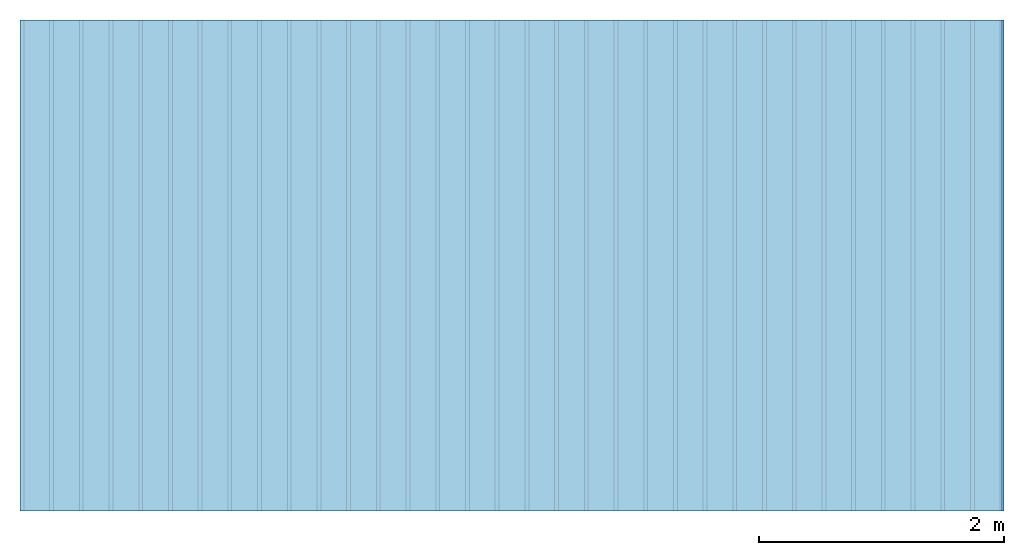
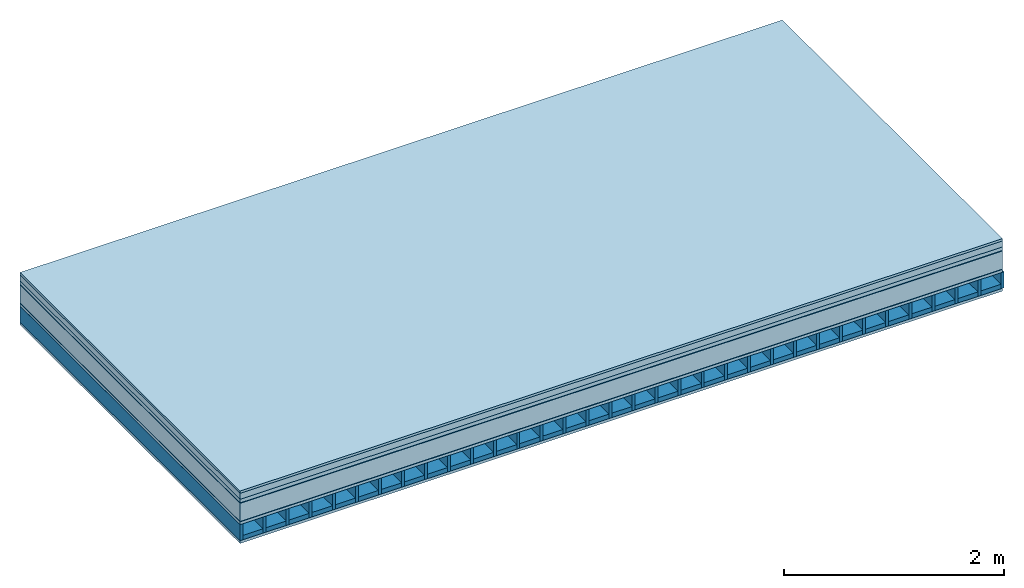
# One storey: 8 plates, 2 members, 1 element without a shape of its own.
"""IFC4 building model written with IfcOpenShell, lengths in metres."""

import ifcopenshell
import ifcopenshell.guid

model = None  # the IFC model being written
_history = None  # IfcOwnerHistory: only IFC2X3 demands one
_inside = {}  # id of a spatial element -> (the spatial element, [elements in it])
_under = {}  # id of a project, library or spatial element -> (it, [spatial elements below it])
_declared = {}  # id of a project -> (the project, [libraries it declares])
_typed = {}  # id of a type object -> (the type object, [elements of that type])
_made_of = {}  # id of a material, layer set ... -> (it, [elements and type objects made of it])


def new_model(schema):
    """Start an empty IFC model of exactly this schema.

    Asked for "IFC4X3", IfcOpenShell would pick the latest addendum, in which some entities
    have other attributes; the version numbers below select the first issue.
    IFC2X3 requires an IfcOwnerHistory on every rooted entity: one is made here for all.
    """
    global model, _history
    if schema == "IFC4X3":
        model = ifcopenshell.file(schema_version=(4, 3, 0, 0))
    else:
        model = ifcopenshell.file(schema=schema)
    _inside.clear()
    _under.clear()
    _declared.clear()
    _typed.clear()
    _made_of.clear()
    _history = None
    if model.schema == "IFC2X3":
        org = make("IfcOrganization", Name="unknown")
        user = make(
            "IfcPersonAndOrganization",
            ThePerson=make("IfcPerson", FamilyName="unknown"),
            TheOrganization=org,
        )
        app = make(
            "IfcApplication",
            ApplicationDeveloper=org,
            Version="unknown",
            ApplicationFullName="unknown",
            ApplicationIdentifier="unknown",
        )
        _history = make(
            "IfcOwnerHistory",
            OwningUser=user,
            OwningApplication=app,
            ChangeAction="ADDED",
            CreationDate=0,
        )
    return model


def make(cls, **values):
    """One entity of the class cls with the attributes given. An attribute that is None is left unset."""
    return model.create_entity(
        cls, **{name: value for name, value in values.items() if value is not None}
    )


def rooted(cls, **values):
    """An entity with a GlobalId (a new one), such as an element, a storey or a relation."""
    return make(cls, GlobalId=ifcopenshell.guid.new(), OwnerHistory=_history, **values)


def si_unit(unit_type, name, prefix=None):
    """IfcSIUnit, for example si_unit("LENGTHUNIT", "METRE", prefix="MILLI")."""
    return make("IfcSIUnit", UnitType=unit_type, Prefix=prefix, Name=name)


def derived_unit(unit_type, elements):
    """IfcDerivedUnit: a product of units, each with its exponent."""
    return make(
        "IfcDerivedUnit",
        Elements=[
            make("IfcDerivedUnitElement", Unit=unit, Exponent=power)
            for unit, power in elements
        ],
        UnitType=unit_type,
    )


def assignment(units):
    """IfcUnitAssignment: the units of a project."""
    return None if units is None else make("IfcUnitAssignment", Units=units)


def point(xyz):
    """IfcCartesianPoint."""
    return None if xyz is None else make("IfcCartesianPoint", Coordinates=xyz)


def direction(xyz):
    """IfcDirection."""
    return None if xyz is None else make("IfcDirection", DirectionRatios=xyz)


def frame(location, z_axis=None, x_axis=None):
    """IfcAxis2Placement3D, a coordinate frame: its origin and axes. An axis left out is left unset."""
    return make(
        "IfcAxis2Placement3D",
        Location=point(location),
        Axis=direction(z_axis),
        RefDirection=direction(x_axis),
    )


def frame_2d(location, x_axis=None):
    """IfcAxis2Placement2D, a coordinate frame in the plane: its origin and x axis."""
    return make(
        "IfcAxis2Placement2D", Location=point(location), RefDirection=direction(x_axis)
    )


def origin():
    """The frame at (0, 0, 0) with its axes left unset."""
    return frame((0.0, 0.0, 0.0))


def origin_with_axes():
    """The frame at (0, 0, 0) with the z axis (0, 0, 1) and the x axis (1, 0, 0) written out."""
    return frame((0.0, 0.0, 0.0), z_axis=(0.0, 0.0, 1.0), x_axis=(1.0, 0.0, 0.0))


def place(relative_to, where):
    """IfcLocalPlacement: puts the frame where relative to a parent placement (None: the world)."""
    return make(
        "IfcLocalPlacement", PlacementRelTo=relative_to, RelativePlacement=where
    )


def context(
    kind, dimensions, precision=None, world=None, true_north=None, identifier=None
):
    """IfcGeometricRepresentationContext, for example the 3D "Model" context."""
    return make(
        "IfcGeometricRepresentationContext",
        ContextIdentifier=identifier,
        ContextType=kind,
        CoordinateSpaceDimension=dimensions,
        Precision=precision,
        WorldCoordinateSystem=world,
        TrueNorth=true_north,
    )


def project(units=None, contexts=None):
    """IfcProject with its units and contexts."""
    return rooted(
        "IfcProject",
        Name="project",
        RepresentationContexts=contexts,
        UnitsInContext=assignment(units),
    )


def spatial(cls, under=None, at=None, **own):
    """A site, building, storey or space (cls), placed at a placement, below another one or the project."""
    s = rooted(cls, ObjectPlacement=at, **own)
    if under is not None:
        _under.setdefault(under.id(), (under, []))[1].append(s)
    return s


def profile(cls, at=None, kind="AREA", **sizes):
    """A parametric profile (cls). Its sizes go by their IFC names, for example OverallWidth=200.0."""
    return make(cls, ProfileType=kind, Position=at, **sizes)


def rectangle(**sizes):
    """IfcRectangleProfileDef."""
    return profile("IfcRectangleProfileDef", **sizes)


def extrude(swept, where, along, depth):
    """IfcExtrudedAreaSolid: the profile swept, set in the frame where, extruded along a direction by depth."""
    return make(
        "IfcExtrudedAreaSolid",
        SweptArea=swept,
        Position=where,
        ExtrudedDirection=direction(along),
        Depth=depth,
    )


def shape(context_of_items, identifier, shape_type, items):
    """IfcShapeRepresentation: the items that make up one representation, for example the "Body"."""
    return make(
        "IfcShapeRepresentation",
        ContextOfItems=context_of_items,
        RepresentationIdentifier=identifier,
        RepresentationType=shape_type,
        Items=items,
    )


def material(Name=None, Category=None):
    """IfcMaterial."""
    return make("IfcMaterial", Name=Name, Category=Category)


def layer(
    of_material, thickness, ventilated=None, Name=None, Category=None, Priority=None
):
    """IfcMaterialLayer: one layer of a wall or slab, of a material (None: an air gap)."""
    return make(
        "IfcMaterialLayer",
        Material=of_material,
        LayerThickness=thickness,
        IsVentilated=ventilated,
        Name=Name,
        Category=Category,
        Priority=Priority,
    )


def layer_set(layers, Name=None):
    """IfcMaterialLayerSet."""
    return make("IfcMaterialLayerSet", MaterialLayers=layers, LayerSetName=Name)


def made_of(thing, what):
    """Note that an element or type object is made of a material, layer set ...; save() writes the relation."""
    if what is not None:
        _made_of.setdefault(what.id(), (what, []))[1].append(thing)
    return thing


def type_object(cls, material=None, **own):
    """A type object (cls), such as IfcWallType, which elements share."""
    return made_of(rooted(cls, **own), material)


def element(
    cls,
    number,
    at=None,
    inside=None,
    cuts=None,
    type_object=None,
    material=None,
    context=None,
    identifier="Body",
    shape_type=None,
    held_by="IfcProductDefinitionShape",
    body=None,
    shapes=None,
    **own,
):
    """One element of the class cls, such as IfcWall. Its Tag is "e" and its number.

    at: its placement. inside: the storey or other place that contains it. cuts: it is an
    opening in that element (IfcRelVoidsElement). A single representation is given by context,
    identifier, shape_type and body (its items); several are given by shapes. held_by: the class
    of the entity that holds the representations. save() writes the other relations.
    """
    e = rooted(cls, Tag="e%d" % number, ObjectPlacement=at, **own)
    if body is not None:
        shapes = [shape(context, identifier, shape_type, body)]
    if shapes is not None:
        e.Representation = make(held_by, Representations=shapes)
    if inside is not None:
        _inside.setdefault(inside.id(), (inside, []))[1].append(e)
    if cuts is not None:
        rooted(
            "IfcRelVoidsElement", RelatingBuildingElement=cuts, RelatedOpeningElement=e
        )
    if type_object is not None:
        _typed.setdefault(type_object.id(), (type_object, []))[1].append(e)
    return made_of(e, material)


def aggregate(whole, parts):
    """IfcRelAggregates: a whole, such as a stair, and the parts it consists of."""
    return rooted("IfcRelAggregates", RelatingObject=whole, RelatedObjects=parts)


def save(model, path):
    """Write the relations noted so far, then the file.

    IfcRelAggregates (storeys below a building ...), IfcRelContainedInSpatialStructure (elements
    in a storey), IfcRelDefinesByType, IfcRelAssociatesMaterial and IfcRelDeclares: one each for
    every whole, place, type object, material and project.
    """
    for whole, parts in _under.values():
        aggregate(whole, parts)
    for where, things in _inside.values():
        rooted(
            "IfcRelContainedInSpatialStructure",
            RelatedElements=things,
            RelatingStructure=where,
        )
    for kind, things in _typed.values():
        rooted("IfcRelDefinesByType", RelatedObjects=things, RelatingType=kind)
    for what, things in _made_of.values():
        rooted("IfcRelAssociatesMaterial", RelatedObjects=things, RelatingMaterial=what)
    for by, libraries in _declared.values():
        rooted("IfcRelDeclares", RelatingContext=by, RelatedDefinitions=libraries)
    model.write(path)


model = new_model("IFC4")

# Units and contexts
plan_context = context("Plan", 3, precision=1e-05, world=origin(), true_north=direction((0.0, 1.0)))
model_context = context("Model", 3, precision=1e-05, world=origin(), true_north=direction((0.0, 1.0)))
ifc_project = project(units=[si_unit("LENGTHUNIT", "METRE"), derived_unit("SOUNDPRESSUREUNIT", [(si_unit("PRESSUREUNIT", "PASCAL", prefix="MICRO"), 0)]), si_unit("ENERGYUNIT", "JOULE", prefix="MEGA"), si_unit("MASSUNIT", "GRAM", prefix="KILO"), derived_unit("THERMALTRANSMITTANCEUNIT", [(si_unit("POWERUNIT", "WATT"), 1), (si_unit("AREAUNIT", "SQUARE_METRE"), -1), (si_unit("THERMODYNAMICTEMPERATUREUNIT", "KELVIN"), -1)]), derived_unit("AREADENSITYUNIT", [(si_unit("MASSUNIT", "GRAM", prefix="KILO"), 1), (si_unit("AREAUNIT", "SQUARE_METRE"), -1)]), derived_unit("USERDEFINED", [(si_unit("ENERGYUNIT", "JOULE", prefix="MEGA"), 1), (si_unit("AREAUNIT", "SQUARE_METRE"), -1)])], contexts=[plan_context, model_context])

# Site, building, storey
site = spatial("IfcSite", under=ifc_project)
building_placement = place(None, origin())
building = spatial("IfcBuilding", under=site, at=building_placement)
storey_placement = place(building_placement, origin())
storey = spatial("IfcBuildingStorey", under=building, at=storey_placement)

# Slab, members, plates
ifc_material_1 = material(Category="07.009")
ifc_layer_1 = layer(ifc_material_1, 0.026, Name="Use and protection layer 3")
ifc_material_2 = material(Category="07.011")
ifc_layer_2 = layer(ifc_material_2, 0.066, Name="Use and protection layer 2")
ifc_material_3 = material(Name="Garden plates", Category="02.007")
ifc_layer_3 = layer(ifc_material_3, 0.04, Name="Use and protection layer 1")
ifc_material_4 = material(Name="Roofing underlay", Category="09.008")
ifc_layer_4 = layer(ifc_material_4, 0.005, Name="Under the roof")
ifc_material_5 = material(Category="10.004")
ifc_layer_5 = layer(ifc_material_5, 0.201, Name="Exterior insulation layer 1")
ifc_material_6 = material(Name="Vapor barrier bituminous", Category="09.003")
ifc_layer_6 = layer(ifc_material_6, 0.004, Name="layer / temporary roof")
ifc_material_7 = material(Name="surface element sheathing above")
ifc_layer_7 = layer(ifc_material_7, 0.031, Name="above 1st layer")
ifc_layer_8 = layer(None, 0.178, Name="Support")
ifc_material_8 = material(Name="surface element sheathing below")
ifc_layer_9 = layer(ifc_material_8, 0.031, Name="Lower layer 1")
ifc_layer_set = layer_set([ifc_layer_1, ifc_layer_2, ifc_layer_3, ifc_layer_4, ifc_layer_5, ifc_layer_6, ifc_layer_7, ifc_layer_8, ifc_layer_9])
slab_type = type_object("IfcSlabType", Name="F0122", PredefinedType="NOTDEFINED", material=ifc_layer_set)
slab_placement = place(None, frame((0.0, 0.0, 0.0), z_axis=(0.0, 0.0, -1.0), x_axis=(1.0, 0.0, 0.0)))
slab = element("IfcSlab", 1, at=slab_placement, inside=storey, type_object=slab_type, material=ifc_layer_set, Name="Slab #1")
ifc_material_9 = material(Name="surface element LFE")
member_1_placement = place(slab_placement, origin())
member_1 = element("IfcMember", 2, at=member_1_placement, material=ifc_material_9, Name="Support", context=plan_context, shape_type="SweptSolid", body=[
    extrude(rectangle(XDim=0.031, YDim=0.178, at=frame_2d((0.0155, 0.089), x_axis=(1.0, 0.0))), frame((0.0, 4.0, 0.373), z_axis=(0.0, -1.0, 0.0), x_axis=(1.0, 0.0, 0.0)), (0.0, 0.0, 1.0), 4.0),
    extrude(rectangle(XDim=0.031, YDim=0.178, at=frame_2d((0.0155, 0.089), x_axis=(1.0, 0.0))), frame((0.242, 4.0, 0.373), z_axis=(0.0, -1.0, 0.0), x_axis=(1.0, 0.0, 0.0)), (0.0, 0.0, 1.0), 4.0),
    extrude(rectangle(XDim=0.031, YDim=0.178, at=frame_2d((0.0155, 0.089), x_axis=(1.0, 0.0))), frame((0.484, 4.0, 0.373), z_axis=(0.0, -1.0, 0.0), x_axis=(1.0, 0.0, 0.0)), (0.0, 0.0, 1.0), 4.0),
    extrude(rectangle(XDim=0.031, YDim=0.178, at=frame_2d((0.0155, 0.089), x_axis=(1.0, 0.0))), frame((0.726, 4.0, 0.373), z_axis=(0.0, -1.0, 0.0), x_axis=(1.0, 0.0, 0.0)), (0.0, 0.0, 1.0), 4.0),
    extrude(rectangle(XDim=0.031, YDim=0.178, at=frame_2d((0.0155, 0.089), x_axis=(1.0, 0.0))), frame((0.968, 4.0, 0.373), z_axis=(0.0, -1.0, 0.0), x_axis=(1.0, 0.0, 0.0)), (0.0, 0.0, 1.0), 4.0),
    extrude(rectangle(XDim=0.031, YDim=0.178, at=frame_2d((0.0155, 0.089), x_axis=(1.0, 0.0))), frame((1.21, 4.0, 0.373), z_axis=(0.0, -1.0, 0.0), x_axis=(1.0, 0.0, 0.0)), (0.0, 0.0, 1.0), 4.0),
    extrude(rectangle(XDim=0.031, YDim=0.178, at=frame_2d((0.0155, 0.089), x_axis=(1.0, 0.0))), frame((1.452, 4.0, 0.373), z_axis=(0.0, -1.0, 0.0), x_axis=(1.0, 0.0, 0.0)), (0.0, 0.0, 1.0), 4.0),
    extrude(rectangle(XDim=0.031, YDim=0.178, at=frame_2d((0.0155, 0.089), x_axis=(1.0, 0.0))), frame((1.694, 4.0, 0.373), z_axis=(0.0, -1.0, 0.0), x_axis=(1.0, 0.0, 0.0)), (0.0, 0.0, 1.0), 4.0),
    extrude(rectangle(XDim=0.031, YDim=0.178, at=frame_2d((0.0155, 0.089), x_axis=(1.0, 0.0))), frame((1.936, 4.0, 0.373), z_axis=(0.0, -1.0, 0.0), x_axis=(1.0, 0.0, 0.0)), (0.0, 0.0, 1.0), 4.0),
    extrude(rectangle(XDim=0.031, YDim=0.178, at=frame_2d((0.0155, 0.089), x_axis=(1.0, 0.0))), frame((2.178, 4.0, 0.373), z_axis=(0.0, -1.0, 0.0), x_axis=(1.0, 0.0, 0.0)), (0.0, 0.0, 1.0), 4.0),
    extrude(rectangle(XDim=0.031, YDim=0.178, at=frame_2d((0.0155, 0.089), x_axis=(1.0, 0.0))), frame((2.42, 4.0, 0.373), z_axis=(0.0, -1.0, 0.0), x_axis=(1.0, 0.0, 0.0)), (0.0, 0.0, 1.0), 4.0),
    extrude(rectangle(XDim=0.031, YDim=0.178, at=frame_2d((0.0155, 0.089), x_axis=(1.0, 0.0))), frame((2.662, 4.0, 0.373), z_axis=(0.0, -1.0, 0.0), x_axis=(1.0, 0.0, 0.0)), (0.0, 0.0, 1.0), 4.0),
    extrude(rectangle(XDim=0.031, YDim=0.178, at=frame_2d((0.0155, 0.089), x_axis=(1.0, 0.0))), frame((2.904, 4.0, 0.373), z_axis=(0.0, -1.0, 0.0), x_axis=(1.0, 0.0, 0.0)), (0.0, 0.0, 1.0), 4.0),
    extrude(rectangle(XDim=0.031, YDim=0.178, at=frame_2d((0.0155, 0.089), x_axis=(1.0, 0.0))), frame((3.146, 4.0, 0.373), z_axis=(0.0, -1.0, 0.0), x_axis=(1.0, 0.0, 0.0)), (0.0, 0.0, 1.0), 4.0),
    extrude(rectangle(XDim=0.031, YDim=0.178, at=frame_2d((0.0155, 0.089), x_axis=(1.0, 0.0))), frame((3.388, 4.0, 0.373), z_axis=(0.0, -1.0, 0.0), x_axis=(1.0, 0.0, 0.0)), (0.0, 0.0, 1.0), 4.0),
    extrude(rectangle(XDim=0.031, YDim=0.178, at=frame_2d((0.0155, 0.089), x_axis=(1.0, 0.0))), frame((3.63, 4.0, 0.373), z_axis=(0.0, -1.0, 0.0), x_axis=(1.0, 0.0, 0.0)), (0.0, 0.0, 1.0), 4.0),
    extrude(rectangle(XDim=0.031, YDim=0.178, at=frame_2d((0.0155, 0.089), x_axis=(1.0, 0.0))), frame((3.872, 4.0, 0.373), z_axis=(0.0, -1.0, 0.0), x_axis=(1.0, 0.0, 0.0)), (0.0, 0.0, 1.0), 4.0),
    extrude(rectangle(XDim=0.031, YDim=0.178, at=frame_2d((0.0155, 0.089), x_axis=(1.0, 0.0))), frame((4.114, 4.0, 0.373), z_axis=(0.0, -1.0, 0.0), x_axis=(1.0, 0.0, 0.0)), (0.0, 0.0, 1.0), 4.0),
    extrude(rectangle(XDim=0.031, YDim=0.178, at=frame_2d((0.0155, 0.089), x_axis=(1.0, 0.0))), frame((4.356, 4.0, 0.373), z_axis=(0.0, -1.0, 0.0), x_axis=(1.0, 0.0, 0.0)), (0.0, 0.0, 1.0), 4.0),
    extrude(rectangle(XDim=0.031, YDim=0.178, at=frame_2d((0.0155, 0.089), x_axis=(1.0, 0.0))), frame((4.598, 4.0, 0.373), z_axis=(0.0, -1.0, 0.0), x_axis=(1.0, 0.0, 0.0)), (0.0, 0.0, 1.0), 4.0),
    extrude(rectangle(XDim=0.031, YDim=0.178, at=frame_2d((0.0155, 0.089), x_axis=(1.0, 0.0))), frame((4.84, 4.0, 0.373), z_axis=(0.0, -1.0, 0.0), x_axis=(1.0, 0.0, 0.0)), (0.0, 0.0, 1.0), 4.0),
    extrude(rectangle(XDim=0.031, YDim=0.178, at=frame_2d((0.0155, 0.089), x_axis=(1.0, 0.0))), frame((5.082, 4.0, 0.373), z_axis=(0.0, -1.0, 0.0), x_axis=(1.0, 0.0, 0.0)), (0.0, 0.0, 1.0), 4.0),
    extrude(rectangle(XDim=0.031, YDim=0.178, at=frame_2d((0.0155, 0.089), x_axis=(1.0, 0.0))), frame((5.324, 4.0, 0.373), z_axis=(0.0, -1.0, 0.0), x_axis=(1.0, 0.0, 0.0)), (0.0, 0.0, 1.0), 4.0),
    extrude(rectangle(XDim=0.031, YDim=0.178, at=frame_2d((0.0155, 0.089), x_axis=(1.0, 0.0))), frame((5.566, 4.0, 0.373), z_axis=(0.0, -1.0, 0.0), x_axis=(1.0, 0.0, 0.0)), (0.0, 0.0, 1.0), 4.0),
    extrude(rectangle(XDim=0.031, YDim=0.178, at=frame_2d((0.0155, 0.089), x_axis=(1.0, 0.0))), frame((5.808, 4.0, 0.373), z_axis=(0.0, -1.0, 0.0), x_axis=(1.0, 0.0, 0.0)), (0.0, 0.0, 1.0), 4.0),
    extrude(rectangle(XDim=0.031, YDim=0.178, at=frame_2d((0.0155, 0.089), x_axis=(1.0, 0.0))), frame((6.05, 4.0, 0.373), z_axis=(0.0, -1.0, 0.0), x_axis=(1.0, 0.0, 0.0)), (0.0, 0.0, 1.0), 4.0),
    extrude(rectangle(XDim=0.031, YDim=0.178, at=frame_2d((0.0155, 0.089), x_axis=(1.0, 0.0))), frame((6.292, 4.0, 0.373), z_axis=(0.0, -1.0, 0.0), x_axis=(1.0, 0.0, 0.0)), (0.0, 0.0, 1.0), 4.0),
    extrude(rectangle(XDim=0.031, YDim=0.178, at=frame_2d((0.0155, 0.089), x_axis=(1.0, 0.0))), frame((6.534, 4.0, 0.373), z_axis=(0.0, -1.0, 0.0), x_axis=(1.0, 0.0, 0.0)), (0.0, 0.0, 1.0), 4.0),
    extrude(rectangle(XDim=0.031, YDim=0.178, at=frame_2d((0.0155, 0.089), x_axis=(1.0, 0.0))), frame((6.776, 4.0, 0.373), z_axis=(0.0, -1.0, 0.0), x_axis=(1.0, 0.0, 0.0)), (0.0, 0.0, 1.0), 4.0),
    extrude(rectangle(XDim=0.031, YDim=0.178, at=frame_2d((0.0155, 0.089), x_axis=(1.0, 0.0))), frame((7.018, 4.0, 0.373), z_axis=(0.0, -1.0, 0.0), x_axis=(1.0, 0.0, 0.0)), (0.0, 0.0, 1.0), 4.0),
    extrude(rectangle(XDim=0.031, YDim=0.178, at=frame_2d((0.0155, 0.089), x_axis=(1.0, 0.0))), frame((7.26, 4.0, 0.373), z_axis=(0.0, -1.0, 0.0), x_axis=(1.0, 0.0, 0.0)), (0.0, 0.0, 1.0), 4.0),
    extrude(rectangle(XDim=0.031, YDim=0.178, at=frame_2d((0.0155, 0.089), x_axis=(1.0, 0.0))), frame((7.502, 4.0, 0.373), z_axis=(0.0, -1.0, 0.0), x_axis=(1.0, 0.0, 0.0)), (0.0, 0.0, 1.0), 4.0),
    extrude(rectangle(XDim=0.031, YDim=0.178, at=frame_2d((0.0155, 0.089), x_axis=(1.0, 0.0))), frame((7.744, 4.0, 0.373), z_axis=(0.0, -1.0, 0.0), x_axis=(1.0, 0.0, 0.0)), (0.0, 0.0, 1.0), 4.0),
    extrude(rectangle(XDim=0.031, YDim=0.178, at=frame_2d((0.0155, 0.089), x_axis=(1.0, 0.0))), frame((7.986, 4.0, 0.373), z_axis=(0.0, -1.0, 0.0), x_axis=(1.0, 0.0, 0.0)), (0.0, 0.0, 1.0), 4.0),
])
ifc_material_10 = material()
member_2_placement = place(slab_placement, origin())
member_2 = element("IfcMember", 3, at=member_2_placement, material=ifc_material_10, Name="in supporting structure", context=plan_context, shape_type="SweptSolid", body=[
    extrude(rectangle(XDim=0.211, YDim=0.049, at=frame_2d((0.1055, 0.0245), x_axis=(1.0, 0.0))), frame((0.031, 4.0, 0.502), z_axis=(0.0, -1.0, 0.0), x_axis=(1.0, 0.0, 0.0)), (0.0, 0.0, 1.0), 4.0),
    extrude(rectangle(XDim=0.211, YDim=0.049, at=frame_2d((0.1055, 0.0245), x_axis=(1.0, 0.0))), frame((0.273, 4.0, 0.502), z_axis=(0.0, -1.0, 0.0), x_axis=(1.0, 0.0, 0.0)), (0.0, 0.0, 1.0), 4.0),
    extrude(rectangle(XDim=0.211, YDim=0.049, at=frame_2d((0.1055, 0.0245), x_axis=(1.0, 0.0))), frame((0.515, 4.0, 0.502), z_axis=(0.0, -1.0, 0.0), x_axis=(1.0, 0.0, 0.0)), (0.0, 0.0, 1.0), 4.0),
    extrude(rectangle(XDim=0.211, YDim=0.049, at=frame_2d((0.1055, 0.0245), x_axis=(1.0, 0.0))), frame((0.757, 4.0, 0.502), z_axis=(0.0, -1.0, 0.0), x_axis=(1.0, 0.0, 0.0)), (0.0, 0.0, 1.0), 4.0),
    extrude(rectangle(XDim=0.211, YDim=0.049, at=frame_2d((0.1055, 0.0245), x_axis=(1.0, 0.0))), frame((0.999, 4.0, 0.502), z_axis=(0.0, -1.0, 0.0), x_axis=(1.0, 0.0, 0.0)), (0.0, 0.0, 1.0), 4.0),
    extrude(rectangle(XDim=0.211, YDim=0.049, at=frame_2d((0.1055, 0.0245), x_axis=(1.0, 0.0))), frame((1.241, 4.0, 0.502), z_axis=(0.0, -1.0, 0.0), x_axis=(1.0, 0.0, 0.0)), (0.0, 0.0, 1.0), 4.0),
    extrude(rectangle(XDim=0.211, YDim=0.049, at=frame_2d((0.1055, 0.0245), x_axis=(1.0, 0.0))), frame((1.483, 4.0, 0.502), z_axis=(0.0, -1.0, 0.0), x_axis=(1.0, 0.0, 0.0)), (0.0, 0.0, 1.0), 4.0),
    extrude(rectangle(XDim=0.211, YDim=0.049, at=frame_2d((0.1055, 0.0245), x_axis=(1.0, 0.0))), frame((1.725, 4.0, 0.502), z_axis=(0.0, -1.0, 0.0), x_axis=(1.0, 0.0, 0.0)), (0.0, 0.0, 1.0), 4.0),
    extrude(rectangle(XDim=0.211, YDim=0.049, at=frame_2d((0.1055, 0.0245), x_axis=(1.0, 0.0))), frame((1.967, 4.0, 0.502), z_axis=(0.0, -1.0, 0.0), x_axis=(1.0, 0.0, 0.0)), (0.0, 0.0, 1.0), 4.0),
    extrude(rectangle(XDim=0.211, YDim=0.049, at=frame_2d((0.1055, 0.0245), x_axis=(1.0, 0.0))), frame((2.209, 4.0, 0.502), z_axis=(0.0, -1.0, 0.0), x_axis=(1.0, 0.0, 0.0)), (0.0, 0.0, 1.0), 4.0),
    extrude(rectangle(XDim=0.211, YDim=0.049, at=frame_2d((0.1055, 0.0245), x_axis=(1.0, 0.0))), frame((2.451, 4.0, 0.502), z_axis=(0.0, -1.0, 0.0), x_axis=(1.0, 0.0, 0.0)), (0.0, 0.0, 1.0), 4.0),
    extrude(rectangle(XDim=0.211, YDim=0.049, at=frame_2d((0.1055, 0.0245), x_axis=(1.0, 0.0))), frame((2.693, 4.0, 0.502), z_axis=(0.0, -1.0, 0.0), x_axis=(1.0, 0.0, 0.0)), (0.0, 0.0, 1.0), 4.0),
    extrude(rectangle(XDim=0.211, YDim=0.049, at=frame_2d((0.1055, 0.0245), x_axis=(1.0, 0.0))), frame((2.935, 4.0, 0.502), z_axis=(0.0, -1.0, 0.0), x_axis=(1.0, 0.0, 0.0)), (0.0, 0.0, 1.0), 4.0),
    extrude(rectangle(XDim=0.211, YDim=0.049, at=frame_2d((0.1055, 0.0245), x_axis=(1.0, 0.0))), frame((3.177, 4.0, 0.502), z_axis=(0.0, -1.0, 0.0), x_axis=(1.0, 0.0, 0.0)), (0.0, 0.0, 1.0), 4.0),
    extrude(rectangle(XDim=0.211, YDim=0.049, at=frame_2d((0.1055, 0.0245), x_axis=(1.0, 0.0))), frame((3.419, 4.0, 0.502), z_axis=(0.0, -1.0, 0.0), x_axis=(1.0, 0.0, 0.0)), (0.0, 0.0, 1.0), 4.0),
    extrude(rectangle(XDim=0.211, YDim=0.049, at=frame_2d((0.1055, 0.0245), x_axis=(1.0, 0.0))), frame((3.661, 4.0, 0.502), z_axis=(0.0, -1.0, 0.0), x_axis=(1.0, 0.0, 0.0)), (0.0, 0.0, 1.0), 4.0),
    extrude(rectangle(XDim=0.211, YDim=0.049, at=frame_2d((0.1055, 0.0245), x_axis=(1.0, 0.0))), frame((3.903, 4.0, 0.502), z_axis=(0.0, -1.0, 0.0), x_axis=(1.0, 0.0, 0.0)), (0.0, 0.0, 1.0), 4.0),
    extrude(rectangle(XDim=0.211, YDim=0.049, at=frame_2d((0.1055, 0.0245), x_axis=(1.0, 0.0))), frame((4.145, 4.0, 0.502), z_axis=(0.0, -1.0, 0.0), x_axis=(1.0, 0.0, 0.0)), (0.0, 0.0, 1.0), 4.0),
    extrude(rectangle(XDim=0.211, YDim=0.049, at=frame_2d((0.1055, 0.0245), x_axis=(1.0, 0.0))), frame((4.387, 4.0, 0.502), z_axis=(0.0, -1.0, 0.0), x_axis=(1.0, 0.0, 0.0)), (0.0, 0.0, 1.0), 4.0),
    extrude(rectangle(XDim=0.211, YDim=0.049, at=frame_2d((0.1055, 0.0245), x_axis=(1.0, 0.0))), frame((4.629, 4.0, 0.502), z_axis=(0.0, -1.0, 0.0), x_axis=(1.0, 0.0, 0.0)), (0.0, 0.0, 1.0), 4.0),
    extrude(rectangle(XDim=0.211, YDim=0.049, at=frame_2d((0.1055, 0.0245), x_axis=(1.0, 0.0))), frame((4.871, 4.0, 0.502), z_axis=(0.0, -1.0, 0.0), x_axis=(1.0, 0.0, 0.0)), (0.0, 0.0, 1.0), 4.0),
    extrude(rectangle(XDim=0.211, YDim=0.049, at=frame_2d((0.1055, 0.0245), x_axis=(1.0, 0.0))), frame((5.113, 4.0, 0.502), z_axis=(0.0, -1.0, 0.0), x_axis=(1.0, 0.0, 0.0)), (0.0, 0.0, 1.0), 4.0),
    extrude(rectangle(XDim=0.211, YDim=0.049, at=frame_2d((0.1055, 0.0245), x_axis=(1.0, 0.0))), frame((5.355, 4.0, 0.502), z_axis=(0.0, -1.0, 0.0), x_axis=(1.0, 0.0, 0.0)), (0.0, 0.0, 1.0), 4.0),
    extrude(rectangle(XDim=0.211, YDim=0.049, at=frame_2d((0.1055, 0.0245), x_axis=(1.0, 0.0))), frame((5.597, 4.0, 0.502), z_axis=(0.0, -1.0, 0.0), x_axis=(1.0, 0.0, 0.0)), (0.0, 0.0, 1.0), 4.0),
    extrude(rectangle(XDim=0.211, YDim=0.049, at=frame_2d((0.1055, 0.0245), x_axis=(1.0, 0.0))), frame((5.839, 4.0, 0.502), z_axis=(0.0, -1.0, 0.0), x_axis=(1.0, 0.0, 0.0)), (0.0, 0.0, 1.0), 4.0),
    extrude(rectangle(XDim=0.211, YDim=0.049, at=frame_2d((0.1055, 0.0245), x_axis=(1.0, 0.0))), frame((6.081, 4.0, 0.502), z_axis=(0.0, -1.0, 0.0), x_axis=(1.0, 0.0, 0.0)), (0.0, 0.0, 1.0), 4.0),
    extrude(rectangle(XDim=0.211, YDim=0.049, at=frame_2d((0.1055, 0.0245), x_axis=(1.0, 0.0))), frame((6.323, 4.0, 0.502), z_axis=(0.0, -1.0, 0.0), x_axis=(1.0, 0.0, 0.0)), (0.0, 0.0, 1.0), 4.0),
    extrude(rectangle(XDim=0.211, YDim=0.049, at=frame_2d((0.1055, 0.0245), x_axis=(1.0, 0.0))), frame((6.565, 4.0, 0.502), z_axis=(0.0, -1.0, 0.0), x_axis=(1.0, 0.0, 0.0)), (0.0, 0.0, 1.0), 4.0),
    extrude(rectangle(XDim=0.211, YDim=0.049, at=frame_2d((0.1055, 0.0245), x_axis=(1.0, 0.0))), frame((6.807, 4.0, 0.502), z_axis=(0.0, -1.0, 0.0), x_axis=(1.0, 0.0, 0.0)), (0.0, 0.0, 1.0), 4.0),
    extrude(rectangle(XDim=0.211, YDim=0.049, at=frame_2d((0.1055, 0.0245), x_axis=(1.0, 0.0))), frame((7.049, 4.0, 0.502), z_axis=(0.0, -1.0, 0.0), x_axis=(1.0, 0.0, 0.0)), (0.0, 0.0, 1.0), 4.0),
    extrude(rectangle(XDim=0.211, YDim=0.049, at=frame_2d((0.1055, 0.0245), x_axis=(1.0, 0.0))), frame((7.291, 4.0, 0.502), z_axis=(0.0, -1.0, 0.0), x_axis=(1.0, 0.0, 0.0)), (0.0, 0.0, 1.0), 4.0),
    extrude(rectangle(XDim=0.211, YDim=0.049, at=frame_2d((0.1055, 0.0245), x_axis=(1.0, 0.0))), frame((7.533, 4.0, 0.502), z_axis=(0.0, -1.0, 0.0), x_axis=(1.0, 0.0, 0.0)), (0.0, 0.0, 1.0), 4.0),
    extrude(rectangle(XDim=0.211, YDim=0.049, at=frame_2d((0.1055, 0.0245), x_axis=(1.0, 0.0))), frame((7.775, 4.0, 0.502), z_axis=(0.0, -1.0, 0.0), x_axis=(1.0, 0.0, 0.0)), (0.0, 0.0, 1.0), 4.0),
])
plate_1_placement = place(slab_placement, origin())
plate_1 = element("IfcPlate", 4, at=plate_1_placement, material=ifc_material_1, Name="Use and protection layer 3", context=plan_context, shape_type="SweptSolid", body=[
    extrude(rectangle(XDim=8.0, YDim=4.0, at=frame_2d((4.0, 2.0), x_axis=(1.0, 0.0))), origin_with_axes(), (0.0, 0.0, 1.0), 0.026),
])
plate_2_placement = place(slab_placement, origin())
plate_2 = element("IfcPlate", 5, at=plate_2_placement, material=ifc_material_2, Name="Use and protection layer 2", context=plan_context, shape_type="SweptSolid", body=[
    extrude(rectangle(XDim=8.0, YDim=4.0, at=frame_2d((4.0, 2.0), x_axis=(1.0, 0.0))), frame((0.0, 0.0, 0.026), z_axis=(0.0, 0.0, 1.0), x_axis=(1.0, 0.0, 0.0)), (0.0, 0.0, 1.0), 0.066),
])
plate_3_placement = place(slab_placement, origin())
plate_3 = element("IfcPlate", 6, at=plate_3_placement, material=ifc_material_3, Name="Use and protection layer 1", context=plan_context, shape_type="SweptSolid", body=[
    extrude(rectangle(XDim=8.0, YDim=4.0, at=frame_2d((4.0, 2.0), x_axis=(1.0, 0.0))), frame((0.0, 0.0, 0.092), z_axis=(0.0, 0.0, 1.0), x_axis=(1.0, 0.0, 0.0)), (0.0, 0.0, 1.0), 0.04),
])
plate_4_placement = place(slab_placement, origin())
plate_4 = element("IfcPlate", 7, at=plate_4_placement, material=ifc_material_4, Name="Under the roof", context=plan_context, shape_type="SweptSolid", body=[
    extrude(rectangle(XDim=8.0, YDim=4.0, at=frame_2d((4.0, 2.0), x_axis=(1.0, 0.0))), frame((0.0, 0.0, 0.132), z_axis=(0.0, 0.0, 1.0), x_axis=(1.0, 0.0, 0.0)), (0.0, 0.0, 1.0), 0.005),
])
plate_5_placement = place(slab_placement, origin())
plate_5 = element("IfcPlate", 8, at=plate_5_placement, material=ifc_material_5, Name="Exterior insulation layer 1", context=plan_context, shape_type="SweptSolid", body=[
    extrude(rectangle(XDim=8.0, YDim=4.0, at=frame_2d((4.0, 2.0), x_axis=(1.0, 0.0))), frame((0.0, 0.0, 0.137), z_axis=(0.0, 0.0, 1.0), x_axis=(1.0, 0.0, 0.0)), (0.0, 0.0, 1.0), 0.201),
])
plate_6_placement = place(slab_placement, origin())
plate_6 = element("IfcPlate", 9, at=plate_6_placement, material=ifc_material_6, Name="layer / temporary roof", context=plan_context, shape_type="SweptSolid", body=[
    extrude(rectangle(XDim=8.0, YDim=4.0, at=frame_2d((4.0, 2.0), x_axis=(1.0, 0.0))), frame((0.0, 0.0, 0.338), z_axis=(0.0, 0.0, 1.0), x_axis=(1.0, 0.0, 0.0)), (0.0, 0.0, 1.0), 0.004),
])
plate_7_placement = place(slab_placement, origin())
plate_7 = element("IfcPlate", 10, at=plate_7_placement, material=ifc_material_7, Name="above 1st layer", context=plan_context, shape_type="SweptSolid", body=[
    extrude(rectangle(XDim=8.0, YDim=4.0, at=frame_2d((4.0, 2.0), x_axis=(1.0, 0.0))), frame((0.0, 0.0, 0.342), z_axis=(0.0, 0.0, 1.0), x_axis=(1.0, 0.0, 0.0)), (0.0, 0.0, 1.0), 0.031),
])
plate_8_placement = place(slab_placement, origin())
plate_8 = element("IfcPlate", 11, at=plate_8_placement, material=ifc_material_8, Name="Lower layer 1", context=plan_context, shape_type="SweptSolid", body=[
    extrude(rectangle(XDim=8.0, YDim=4.0, at=frame_2d((4.0, 2.0), x_axis=(1.0, 0.0))), frame((0.0, 0.0, 0.551), z_axis=(0.0, 0.0, 1.0), x_axis=(1.0, 0.0, 0.0)), (0.0, 0.0, 1.0), 0.031),
])
aggregate(slab, [plate_1, plate_2, plate_3, plate_4, plate_5, plate_6, plate_7, member_1, member_2, plate_8])

save(model, "model.ifc")
